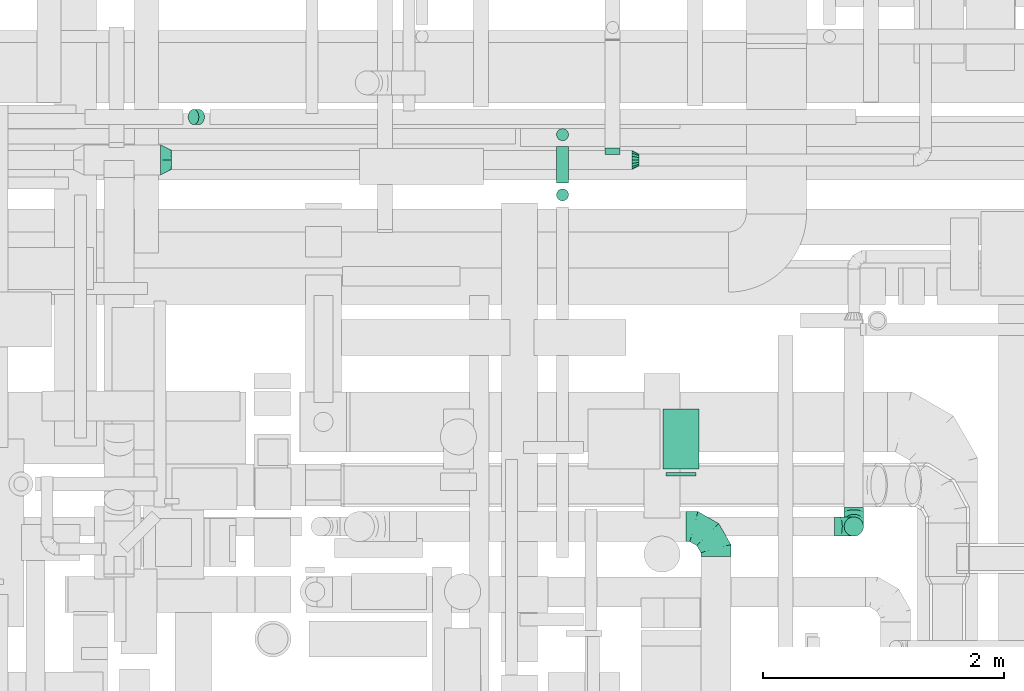
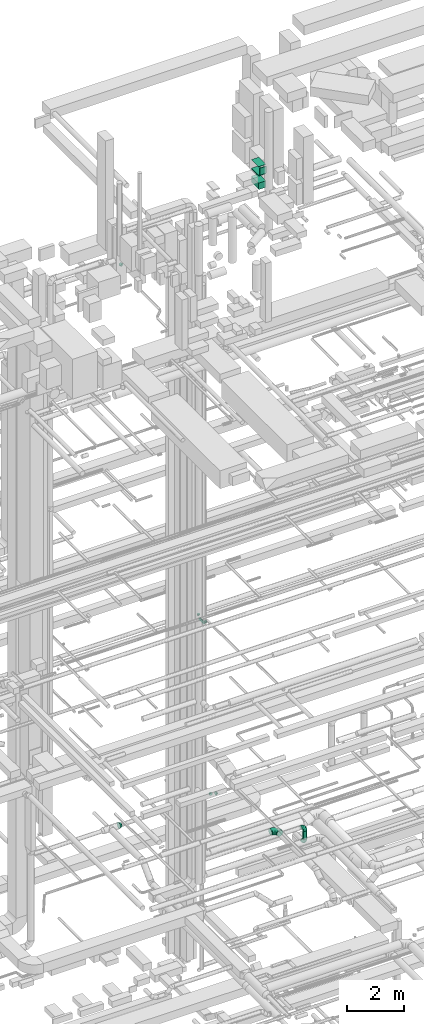
# One storey, part 148 of 337: 9 flow segments, 6 flow fittings.
"""IFC2X3 building model written with IfcOpenShell, lengths in millimetres."""

from ifc_helpers import new_model, entity, si_unit, converted_unit, derived_unit, direction, frame, origin, origin_2d_with_axis, place, context, subcontext, project, spatial, rectangle, circle, extrude, faceted_brep, source, transform, mapped, material, type_object, type_shapes, element, save


model = new_model("IFC2X3")

# Units and contexts
model_context = context("Model", 3, precision=0.01, world=origin(), true_north=direction((6.12303176911189e-17, 1.0)))
body_context = subcontext(model_context, "Body", "Model", "MODEL_VIEW")
ifc_project = project(units=[si_unit("LENGTHUNIT", "METRE", prefix="MILLI"), si_unit("AREAUNIT", "SQUARE_METRE"), si_unit("VOLUMEUNIT", "CUBIC_METRE"), converted_unit("PLANEANGLEUNIT", "DEGREE", entity("IfcRatioMeasure", 0.0174532925199433), si_unit("PLANEANGLEUNIT", "RADIAN"), dimensions=[0, 0, 0, 0, 0, 0, 0]), si_unit("MASSUNIT", "GRAM", prefix="KILO"), derived_unit("MASSDENSITYUNIT", [(si_unit("MASSUNIT", "GRAM", prefix="KILO"), 1), (si_unit("LENGTHUNIT", "METRE"), -3)]), derived_unit("MOMENTOFINERTIAUNIT", [(si_unit("LENGTHUNIT", "METRE"), 4)]), si_unit("TIMEUNIT", "SECOND"), si_unit("FREQUENCYUNIT", "HERTZ"), si_unit("THERMODYNAMICTEMPERATUREUNIT", "DEGREE_CELSIUS"), derived_unit("THERMALTRANSMITTANCEUNIT", [(si_unit("MASSUNIT", "GRAM", prefix="KILO"), 1), (si_unit("THERMODYNAMICTEMPERATUREUNIT", "KELVIN"), -1), (si_unit("TIMEUNIT", "SECOND"), -3)]), derived_unit("VOLUMETRICFLOWRATEUNIT", [(si_unit("LENGTHUNIT", "METRE"), 3), (si_unit("TIMEUNIT", "SECOND"), -1)]), derived_unit("MASSFLOWRATEUNIT", [(si_unit("MASSUNIT", "GRAM", prefix="KILO"), 1), (si_unit("TIMEUNIT", "SECOND"), -1)]), derived_unit("ROTATIONALFREQUENCYUNIT", [(si_unit("TIMEUNIT", "SECOND"), -1)]), si_unit("ELECTRICCURRENTUNIT", "AMPERE"), si_unit("ELECTRICVOLTAGEUNIT", "VOLT"), si_unit("POWERUNIT", "WATT"), si_unit("FORCEUNIT", "NEWTON", prefix="KILO"), si_unit("ILLUMINANCEUNIT", "LUX"), si_unit("LUMINOUSFLUXUNIT", "LUMEN"), si_unit("LUMINOUSINTENSITYUNIT", "CANDELA"), derived_unit("USERDEFINED", [(si_unit("MASSUNIT", "GRAM", prefix="KILO"), -1), (si_unit("LENGTHUNIT", "METRE"), -2), (si_unit("TIMEUNIT", "SECOND"), 3), (si_unit("LUMINOUSFLUXUNIT", "LUMEN"), 1)]), derived_unit("LINEARVELOCITYUNIT", [(si_unit("LENGTHUNIT", "METRE"), 1), (si_unit("TIMEUNIT", "SECOND"), -1)]), si_unit("PRESSUREUNIT", "PASCAL"), derived_unit("USERDEFINED", [(si_unit("LENGTHUNIT", "METRE"), -2), (si_unit("MASSUNIT", "GRAM", prefix="KILO"), 1), (si_unit("TIMEUNIT", "SECOND"), -2)]), derived_unit("LINEARFORCEUNIT", [(si_unit("MASSUNIT", "GRAM", prefix="KILO"), 1), (si_unit("LENGTHUNIT", "METRE"), 1), (si_unit("TIMEUNIT", "SECOND"), -2), (si_unit("LENGTHUNIT", "METRE"), -1)]), derived_unit("PLANARFORCEUNIT", [(si_unit("MASSUNIT", "GRAM", prefix="KILO"), 1), (si_unit("LENGTHUNIT", "METRE"), 1), (si_unit("TIMEUNIT", "SECOND"), -2), (si_unit("LENGTHUNIT", "METRE"), -2)])], contexts=[model_context])

# Site, building, storey
site_placement = place(None, origin())
site = spatial("IfcSite", under=ifc_project, at=site_placement, CompositionType="ELEMENT")
building_placement = place(site_placement, origin())
building = spatial("IfcBuilding", under=site, at=building_placement, CompositionType="ELEMENT")
storey_placement = place(building_placement, origin())
storey = spatial("IfcBuildingStorey", under=building, at=storey_placement, CompositionType="ELEMENT", Elevation=0.0)

# Flow segments
duct_segment_type_1 = type_object("IfcDuctSegmentType", PredefinedType="NOTDEFINED")
flow_segment_1_placement = place(storey_placement, frame((34379.03, 12654.98, 31840.0)))
element("IfcFlowSegment", 1, at=flow_segment_1_placement, inside=storey, type_object=duct_segment_type_1, context=body_context, shape_type="SweptSolid", body=[
    extrude(rectangle(XDim=499.999999999999, YDim=300.000000000001, at=origin_2d_with_axis()), frame((150.0, 250.0, 0.0), z_axis=(0.0, 0.0, 1.0), x_axis=(0.0, -1.0, 0.0)), (0.0, 0.0, 1.0), 15.0000000012614),
])
flow_segment_2_placement = place(storey_placement, frame((34379.03, 12654.98, 30875.0)))
element("IfcFlowSegment", 2, at=flow_segment_2_placement, inside=storey, type_object=duct_segment_type_1, context=body_context, shape_type="SweptSolid", body=[
    extrude(rectangle(XDim=499.999999999999, YDim=300.000000000001, at=origin_2d_with_axis()), frame((150.0, 250.0, 0.0), z_axis=(0.0, 0.0, 1.0), x_axis=(0.0, 1.0, 0.0)), (0.0, 0.0, 1.0), 275.000025000013),
])
flow_segment_3_placement = place(storey_placement, frame((34379.03, 12654.98, 31450.0)))
element("IfcFlowSegment", 3, at=flow_segment_3_placement, inside=storey, type_object=duct_segment_type_1, context=body_context, shape_type="SweptSolid", body=[
    extrude(rectangle(XDim=499.999999999999, YDim=300.000000000001, at=origin_2d_with_axis()), frame((150.0, 250.0, 0.0), z_axis=(0.0, 0.0, 1.0), x_axis=(0.0, 1.0, 0.0)), (0.0, 0.0, 1.0), 39.9999749988413),
])
duct_segment_type_2 = type_object("IfcDuctSegmentType", PredefinedType="NOTDEFINED")
flow_segment_4_placement = place(storey_placement, frame((33494.61, 15383.25, 11300.0)))
element("IfcFlowSegment", 4, at=flow_segment_4_placement, inside=storey, type_object=duct_segment_type_2, context=body_context, shape_type="SweptSolid", body=[
    extrude(circle(Radius=50.0, at=origin_2d_with_axis()), frame((51.6, 51.6, 0.0), z_axis=(0.0, 0.0, 1.0), x_axis=(-1.0, 0.0, 0.0)), (0.0, 0.0, 1.0), 49.9999999999713),
])
flow_segment_5_placement = place(storey_placement, frame((33494.61, 15034.85, 11148.4)))
element("IfcFlowSegment", 5, at=flow_segment_5_placement, inside=storey, type_object=duct_segment_type_2, context=body_context, shape_type="SweptSolid", body=[
    extrude(circle(Radius=50.0, at=origin_2d_with_axis()), frame((51.6, 0.0, 51.6), z_axis=(0.0, 1.0, 0.0), x_axis=(-1.0, 0.0, 0.0)), (0.0, 0.0, 1.0), 300.000000000005),
])
flow_segment_6_placement = place(storey_placement, frame((33494.61, 14883.25, 11300.0)))
element("IfcFlowSegment", 6, at=flow_segment_6_placement, inside=storey, type_object=duct_segment_type_2, context=body_context, shape_type="SweptSolid", body=[
    extrude(circle(Radius=50.0, at=origin_2d_with_axis()), frame((51.6, 51.6, 0.0), z_axis=(0.0, 0.0, 1.0), x_axis=(-1.0, 0.0, 0.0)), (0.0, 0.0, 1.0), 50.000000000019),
])
flow_segment_7_placement = place(storey_placement, frame((35884.48, 12097.06, 2880.0)))
element("IfcFlowSegment", 7, at=flow_segment_7_placement, inside=storey, type_object=duct_segment_type_2, context=body_context, shape_type="SweptSolid", body=[
    extrude(circle(Radius=80.0, at=origin_2d_with_axis()), frame((81.6, 81.6, 0.0), z_axis=(0.0, 0.0, 1.0), x_axis=(0.0, 1.0, 0.0)), (0.0, 0.0, 1.0), 360.000000000001),
])
flow_segment_8_placement = place(storey_placement, frame((30434.24, 15517.89, 27190.82)))
element("IfcFlowSegment", 8, at=flow_segment_8_placement, inside=storey, type_object=duct_segment_type_2, context=body_context, shape_type="SweptSolid", body=[
    extrude(circle(Radius=62.5, at=origin_2d_with_axis()), frame((45.79, 64.1, 92.57), z_axis=(0.707106074078693, 0.0, -0.707107488293695), x_axis=(0.0, 1.0, 0.0)), (0.0, 0.0, 1.0), 66.1519207391797),
])
duct_segment_type_3 = type_object("IfcDuctSegmentType", PredefinedType="NOTDEFINED")
flow_segment_9_placement = place(storey_placement, frame((34404.03, 12599.6, 31515.0)))
element("IfcFlowSegment", 9, at=flow_segment_9_placement, inside=storey, type_object=duct_segment_type_3, context=body_context, shape_type="SweptSolid", body=[
    extrude(rectangle(XDim=30.3811905327621, YDim=249.999999999999, at=origin_2d_with_axis()), frame((125.0, 15.19, 0.0), z_axis=(0.0, 0.0, 1.0), x_axis=(0.0, 1.0, 0.0)), (0.0, 0.0, 1.0), 300.000000000001),
])

# Flow fittings
ifc_material = material()
duct_fitting_type_1 = type_object("IfcDuctFittingType", PredefinedType="NOTDEFINED", material=ifc_material)
shared_shape_1 = source(origin(), body_context, "Body", "Brep", [
    faceted_brep([(-160.0, 0.0, -80.0), (-160.0, -20.71, -77.27), (-160.0, -40.0, -69.28), (-160.0, -56.57, -56.57), (-160.0, -69.28, -40.0), (-160.0, -77.27, -20.71), (-160.0, -80.0, 0.0), (-160.0, -77.27, 20.71), (-160.0, -69.28, 40.0), (-160.0, -56.57, 56.57), (-160.0, -40.0, 69.28), (-160.0, -20.71, 77.27), (-160.0, 0.0, 80.0), (-160.0, 20.71, 77.27), (-160.0, 40.0, 69.28), (-160.0, 56.57, 56.57), (-160.0, 69.28, 40.0), (-160.0, 77.27, 20.71), (-160.0, 80.0, 0.0), (-160.0, 77.27, -20.71), (-160.0, 69.28, -40.0), (-160.0, 56.57, -56.57), (-160.0, 40.0, -69.28), (-160.0, 20.71, -77.27), (-122.68, 20.71, 77.27), (-127.85, 40.0, 69.28), (-117.13, 0.0, 80.0), (-132.29, 56.57, 56.57), (-137.83, 77.27, 20.71), (-138.56, 80.0, 0.0), (-135.69, 69.28, 40.0), (-135.69, 69.28, -40.0), (-132.29, 56.57, -56.57), (-137.83, 77.27, -20.71), (-122.68, 20.71, -77.27), (-117.13, 0.0, -80.0), (-127.85, 40.0, -69.28), (-111.58, -20.71, -77.27), (-106.41, -40.0, -69.28), (-101.97, -56.57, -56.57), (-98.56, -69.28, -40.0), (-96.42, -77.27, -20.71), (-95.69, -80.0, 0.0), (-96.42, -77.27, 20.71), (-98.56, -69.28, 40.0), (-101.97, -56.57, 56.57), (-106.41, -40.0, 69.28), (-111.58, -20.71, 77.27), (-58.03, 58.03, 77.27), (-72.15, 72.15, 69.28), (-42.87, 42.87, 80.0), (-84.28, 84.28, 56.57), (-93.59, 93.59, 40.0), (-99.44, 99.44, 20.71), (-101.44, 101.44, 0.0), (-99.44, 99.44, -20.71), (-93.59, 93.59, -40.0), (-84.28, 84.28, -56.57), (-58.03, 58.03, -77.27), (-42.87, 42.87, -80.0), (-72.15, 72.15, -69.28), (-27.71, 27.71, -77.27), (-13.59, 13.59, -69.28), (-1.46, 1.46, -56.57), (7.85, -7.85, -40.0), (13.7, -13.7, -20.71), (15.69, -15.69, 0.0), (13.7, -13.7, 20.71), (7.85, -7.85, 40.0), (-1.46, 1.46, 56.57), (-13.59, 13.59, 69.28), (-27.71, 27.71, 77.27), (-20.71, 122.68, 77.27), (-40.0, 127.85, 69.28), (0.0, 117.13, 80.0), (-56.57, 132.29, 56.57), (-69.28, 135.69, 40.0), (-77.27, 137.83, 20.71), (-80.0, 138.56, 0.0), (-77.27, 137.83, -20.71), (-69.28, 135.69, -40.0), (-56.57, 132.29, -56.57), (-20.71, 122.68, -77.27), (0.0, 117.13, -80.0), (-40.0, 127.85, -69.28), (20.71, 111.58, -77.27), (40.0, 106.41, -69.28), (56.57, 101.97, -56.57), (69.28, 98.56, -40.0), (77.27, 96.42, -20.71), (80.0, 95.69, 0.0), (77.27, 96.42, 20.71), (69.28, 98.56, 40.0), (56.57, 101.97, 56.57), (40.0, 106.41, 69.28), (20.71, 111.58, 77.27), (-20.71, 160.0, -77.27), (-40.0, 160.0, -69.28), (-56.57, 160.0, -56.57), (-69.28, 160.0, -40.0), (-77.27, 160.0, -20.71), (-80.0, 160.0, 0.0), (-77.27, 160.0, 20.71), (-69.28, 160.0, 40.0), (-56.57, 160.0, 56.57), (-40.0, 160.0, 69.28), (-20.71, 160.0, 77.27), (0.0, 160.0, 80.0), (20.71, 160.0, 77.27), (40.0, 160.0, 69.28), (56.57, 160.0, 56.57), (69.28, 160.0, 40.0), (77.27, 160.0, 20.71), (80.0, 160.0, 0.0), (77.27, 160.0, -20.71), (69.28, 160.0, -40.0), (56.57, 160.0, -56.57), (40.0, 160.0, -69.28), (20.71, 160.0, -77.27), (0.0, 160.0, -80.0)], [[[0, 1, 2, 3, 4, 5, 6, 7, 8, 9, 10, 11, 12, 13, 14, 15, 16, 17, 18, 19, 20, 21, 22, 23]], [[24, 25, 14, 13]], [[26, 24, 13, 12]], [[14, 25, 27, 15]], [[28, 29, 18, 17]], [[30, 28, 17, 16]], [[15, 27, 30, 16]], [[20, 31, 32, 21]], [[33, 31, 20, 19]], [[18, 29, 33, 19]], [[34, 35, 0, 23]], [[36, 34, 23, 22]], [[32, 36, 22, 21]], [[1, 0, 35, 37]], [[2, 1, 37, 38]], [[3, 2, 38, 39]], [[5, 4, 40, 41]], [[6, 5, 41, 42]], [[39, 40, 4, 3]], [[6, 42, 43, 7]], [[7, 43, 44, 8]], [[8, 44, 45, 9]], [[9, 45, 46, 10]], [[10, 46, 47, 11]], [[26, 12, 11, 47]], [[48, 49, 25, 24]], [[50, 48, 24, 26]], [[27, 25, 49, 51]], [[52, 53, 28, 30]], [[51, 52, 30, 27]], [[29, 28, 53, 54]], [[55, 56, 31, 33]], [[54, 55, 33, 29]], [[32, 31, 56, 57]], [[58, 59, 35, 34]], [[60, 58, 34, 36]], [[57, 60, 36, 32]], [[37, 35, 59, 61]], [[38, 37, 61, 62]], [[39, 38, 62, 63]], [[41, 40, 64, 65]], [[42, 41, 65, 66]], [[63, 64, 40, 39]], [[43, 42, 66, 67]], [[44, 43, 67, 68]], [[68, 69, 45, 44]], [[46, 45, 69, 70]], [[47, 46, 70, 71]], [[26, 47, 71, 50]], [[72, 73, 49, 48]], [[74, 72, 48, 50]], [[51, 49, 73, 75]], [[76, 77, 53, 52]], [[75, 76, 52, 51]], [[54, 53, 77, 78]], [[79, 80, 56, 55]], [[78, 79, 55, 54]], [[57, 56, 80, 81]], [[82, 83, 59, 58]], [[84, 82, 58, 60]], [[81, 84, 60, 57]], [[61, 59, 83, 85]], [[62, 61, 85, 86]], [[63, 62, 86, 87]], [[65, 64, 88, 89]], [[66, 65, 89, 90]], [[87, 88, 64, 63]], [[67, 66, 90, 91]], [[68, 67, 91, 92]], [[92, 93, 69, 68]], [[70, 69, 93, 94]], [[71, 70, 94, 95]], [[50, 71, 95, 74]], [[96, 97, 98, 99, 100, 101, 102, 103, 104, 105, 106, 107, 108, 109, 110, 111, 112, 113, 114, 115, 116, 117, 118, 119]], [[72, 74, 107, 106]], [[73, 72, 106, 105]], [[75, 73, 105, 104]], [[77, 76, 103, 102]], [[78, 77, 102, 101]], [[75, 104, 103, 76]], [[78, 101, 100, 79]], [[79, 100, 99, 80]], [[80, 99, 98, 81]], [[84, 97, 96, 82]], [[82, 96, 119, 83]], [[84, 81, 98, 97]], [[118, 117, 86, 85]], [[119, 118, 85, 83]], [[116, 87, 86, 117]], [[88, 115, 114, 89]], [[89, 114, 113, 90]], [[115, 88, 87, 116]], [[112, 111, 92, 91]], [[113, 112, 91, 90]], [[111, 110, 93, 92]], [[95, 94, 109, 108]], [[74, 95, 108, 107]], [[110, 109, 94, 93]]]),
])
type_shapes(duct_fitting_type_1, [shared_shape_1])
for number, where, z_axis, x_axis in (
    (10, (35966.08, 12178.65, 2720.0), (-1.0, 0.0, 0.0), (0.0, -1.0, 0.0)),
    (11, (35966.08, 12178.65, 3400.0), (0.0, -1.0, 0.0), (0.0, 0.0, 1.0)),
):
    element("IfcFlowFitting", number, at=place(storey_placement, frame(where, z_axis=z_axis, x_axis=x_axis)), inside=storey, type_object=duct_fitting_type_1, material=ifc_material, context=body_context, shape_type="MappedRepresentation", body=[
        mapped(shared_shape_1, transform((0.0, 0.0, 0.0), scale=1.0)),
    ])
duct_fitting_type_2 = type_object("IfcDuctFittingType", PredefinedType="NOTDEFINED", material=ifc_material)
shared_shape_2 = source(origin(), body_context, "Body", "Brep", [
    faceted_brep([(-250.0, 0.0, -125.0), (-250.0, -32.35, -120.74), (-250.0, -62.5, -108.25), (-250.0, -88.39, -88.39), (-250.0, -108.25, -62.5), (-250.0, -120.74, -32.35), (-250.0, -125.0, 0.0), (-250.0, -120.74, 32.35), (-250.0, -108.25, 62.5), (-250.0, -88.39, 88.39), (-250.0, -62.5, 108.25), (-250.0, -32.35, 120.74), (-250.0, 0.0, 125.0), (-250.0, 32.35, 120.74), (-250.0, 62.5, 108.25), (-250.0, 88.39, 88.39), (-250.0, 108.25, 62.5), (-250.0, 120.74, 32.35), (-250.0, 125.0, 0.0), (-250.0, 120.74, -32.35), (-250.0, 108.25, -62.5), (-250.0, 88.39, -88.39), (-250.0, 62.5, -108.25), (-250.0, 32.35, -120.74), (-191.68, 32.35, 120.74), (-199.76, 62.5, 108.25), (-183.01, 0.0, 125.0), (-206.7, 88.39, 88.39), (-215.37, 120.74, 32.35), (-216.51, 125.0, 0.0), (-212.02, 108.25, 62.5), (-212.02, 108.25, -62.5), (-206.7, 88.39, -88.39), (-215.37, 120.74, -32.35), (-191.68, 32.35, -120.74), (-183.01, 0.0, -125.0), (-199.76, 62.5, -108.25), (-174.34, -32.35, -120.74), (-166.27, -62.5, -108.25), (-159.33, -88.39, -88.39), (-154.01, -108.25, -62.5), (-150.66, -120.74, -32.35), (-149.52, -125.0, 0.0), (-150.66, -120.74, 32.35), (-154.01, -108.25, 62.5), (-159.33, -88.39, 88.39), (-166.27, -62.5, 108.25), (-174.34, -32.35, 120.74), (-90.67, 90.67, 120.74), (-112.74, 112.74, 108.25), (-66.99, 66.99, 125.0), (-131.69, 131.69, 88.39), (-146.23, 146.23, 62.5), (-155.38, 155.38, 32.35), (-158.49, 158.49, 0.0), (-155.38, 155.38, -32.35), (-146.23, 146.23, -62.5), (-131.69, 131.69, -88.39), (-90.67, 90.67, -120.74), (-66.99, 66.99, -125.0), (-112.74, 112.74, -108.25), (-43.3, 43.3, -120.74), (-21.23, 21.23, -108.25), (-2.28, 2.28, -88.39), (12.26, -12.26, -62.5), (21.4, -21.4, -32.35), (24.52, -24.52, 0.0), (21.4, -21.4, 32.35), (12.26, -12.26, 62.5), (-2.28, 2.28, 88.39), (-21.23, 21.23, 108.25), (-43.3, 43.3, 120.74), (-32.35, 191.68, 120.74), (-62.5, 199.76, 108.25), (0.0, 183.01, 125.0), (-88.39, 206.7, 88.39), (-108.25, 212.02, 62.5), (-120.74, 215.37, 32.35), (-125.0, 216.51, 0.0), (-120.74, 215.37, -32.35), (-108.25, 212.02, -62.5), (-88.39, 206.7, -88.39), (-32.35, 191.68, -120.74), (0.0, 183.01, -125.0), (-62.5, 199.76, -108.25), (32.35, 174.34, -120.74), (62.5, 166.27, -108.25), (88.39, 159.33, -88.39), (108.25, 154.01, -62.5), (120.74, 150.66, -32.35), (125.0, 149.52, 0.0), (120.74, 150.66, 32.35), (108.25, 154.01, 62.5), (88.39, 159.33, 88.39), (62.5, 166.27, 108.25), (32.35, 174.34, 120.74), (-32.35, 250.0, -120.74), (-62.5, 250.0, -108.25), (-88.39, 250.0, -88.39), (-108.25, 250.0, -62.5), (-120.74, 250.0, -32.35), (-125.0, 250.0, 0.0), (-120.74, 250.0, 32.35), (-108.25, 250.0, 62.5), (-88.39, 250.0, 88.39), (-62.5, 250.0, 108.25), (-32.35, 250.0, 120.74), (0.0, 250.0, 125.0), (32.35, 250.0, 120.74), (62.5, 250.0, 108.25), (88.39, 250.0, 88.39), (108.25, 250.0, 62.5), (120.74, 250.0, 32.35), (125.0, 250.0, 0.0), (120.74, 250.0, -32.35), (108.25, 250.0, -62.5), (88.39, 250.0, -88.39), (62.5, 250.0, -108.25), (32.35, 250.0, -120.74), (0.0, 250.0, -125.0)], [[[0, 1, 2, 3, 4, 5, 6, 7, 8, 9, 10, 11, 12, 13, 14, 15, 16, 17, 18, 19, 20, 21, 22, 23]], [[24, 25, 14, 13]], [[26, 24, 13, 12]], [[14, 25, 27, 15]], [[28, 29, 18, 17]], [[30, 28, 17, 16]], [[15, 27, 30, 16]], [[20, 31, 32, 21]], [[33, 31, 20, 19]], [[18, 29, 33, 19]], [[34, 35, 0, 23]], [[36, 34, 23, 22]], [[21, 32, 36, 22]], [[1, 0, 35, 37]], [[2, 1, 37, 38]], [[38, 39, 3, 2]], [[5, 4, 40, 41]], [[6, 5, 41, 42]], [[39, 40, 4, 3]], [[6, 42, 43, 7]], [[7, 43, 44, 8]], [[8, 44, 45, 9]], [[9, 45, 46, 10]], [[10, 46, 47, 11]], [[26, 12, 11, 47]], [[48, 49, 25, 24]], [[50, 48, 24, 26]], [[27, 25, 49, 51]], [[52, 53, 28, 30]], [[51, 52, 30, 27]], [[29, 28, 53, 54]], [[55, 56, 31, 33]], [[54, 55, 33, 29]], [[32, 31, 56, 57]], [[58, 59, 35, 34]], [[60, 58, 34, 36]], [[57, 60, 36, 32]], [[37, 35, 59, 61]], [[38, 37, 61, 62]], [[39, 38, 62, 63]], [[41, 40, 64, 65]], [[42, 41, 65, 66]], [[63, 64, 40, 39]], [[43, 42, 66, 67]], [[44, 43, 67, 68]], [[68, 69, 45, 44]], [[46, 45, 69, 70]], [[47, 46, 70, 71]], [[26, 47, 71, 50]], [[72, 73, 49, 48]], [[74, 72, 48, 50]], [[51, 49, 73, 75]], [[76, 77, 53, 52]], [[75, 76, 52, 51]], [[54, 53, 77, 78]], [[79, 80, 56, 55]], [[78, 79, 55, 54]], [[57, 56, 80, 81]], [[82, 83, 59, 58]], [[84, 82, 58, 60]], [[81, 84, 60, 57]], [[61, 59, 83, 85]], [[62, 61, 85, 86]], [[63, 62, 86, 87]], [[65, 64, 88, 89]], [[66, 65, 89, 90]], [[87, 88, 64, 63]], [[67, 66, 90, 91]], [[68, 67, 91, 92]], [[92, 93, 69, 68]], [[70, 69, 93, 94]], [[71, 70, 94, 95]], [[50, 71, 95, 74]], [[96, 97, 98, 99, 100, 101, 102, 103, 104, 105, 106, 107, 108, 109, 110, 111, 112, 113, 114, 115, 116, 117, 118, 119]], [[72, 74, 107, 106]], [[73, 72, 106, 105]], [[75, 73, 105, 104]], [[77, 76, 103, 102]], [[78, 77, 102, 101]], [[75, 104, 103, 76]], [[78, 101, 100, 79]], [[79, 100, 99, 80]], [[80, 99, 98, 81]], [[84, 97, 96, 82]], [[82, 96, 119, 83]], [[84, 81, 98, 97]], [[83, 119, 118, 85]], [[85, 118, 117, 86]], [[116, 87, 86, 117]], [[88, 115, 114, 89]], [[89, 114, 113, 90]], [[115, 88, 87, 116]], [[91, 90, 113, 112]], [[92, 91, 112, 111]], [[111, 110, 93, 92]], [[95, 94, 109, 108]], [[74, 95, 108, 107]], [[110, 109, 94, 93]]]),
])
type_shapes(duct_fitting_type_2, [shared_shape_2])
flow_fitting_1_placement = place(storey_placement, frame((34820.41, 12178.65, 3650.0), z_axis=(0.0, 0.0, 1.0), x_axis=(0.0, 1.0, 0.0)))
element("IfcFlowFitting", 12, at=flow_fitting_1_placement, inside=storey, type_object=duct_fitting_type_2, material=ifc_material, context=body_context, shape_type="MappedRepresentation", body=[
    mapped(shared_shape_2, transform((0.0, 0.0, 0.0), scale=1.0)),
])
duct_fitting_type_3 = type_object("IfcDuctFittingType", PredefinedType="NOTDEFINED", material=ifc_material)
shared_shape_3 = source(origin(), body_context, "Body", "Brep", [
    faceted_brep([(60.0, 0.0, -80.0), (60.0, 14.27, -77.16), (60.0, 30.61, -73.91), (60.0, 43.59, -65.24), (60.0, 56.57, -56.57), (60.0, 65.24, -43.59), (60.0, 73.91, -30.61), (60.0, 77.16, -14.27), (60.0, 80.0, 0.0), (60.0, 77.16, 14.27), (60.0, 73.91, 30.61), (60.0, 65.24, 43.59), (60.0, 56.57, 56.57), (60.0, 43.59, 65.24), (60.0, 30.61, 73.91), (60.0, 14.27, 77.16), (60.0, 0.0, 80.0), (60.0, -14.27, 77.16), (60.0, -30.61, 73.91), (60.0, -43.59, 65.24), (60.0, -56.57, 56.57), (60.0, -65.24, 43.59), (60.0, -73.91, 30.61), (60.0, -77.16, 14.27), (60.0, -80.0, 0.0), (60.0, -77.16, -14.27), (60.0, -73.91, -30.61), (60.0, -65.24, -43.59), (60.0, -56.57, -56.57), (60.0, -43.59, -65.24), (60.0, -30.61, -73.91), (60.0, -14.27, -77.16), (0.0, -19.13, -46.19), (0.0, -27.24, -40.77), (0.0, -35.36, -35.36), (0.0, -40.77, -27.24), (0.0, -46.19, -19.13), (0.0, -48.1, -9.57), (0.0, -50.0, 0.0), (0.0, -48.1, 9.57), (0.0, -46.19, 19.13), (0.0, -40.77, 27.24), (0.0, -35.36, 35.36), (0.0, -27.24, 40.77), (0.0, -19.13, 46.19), (0.0, -9.57, 48.1), (0.0, 0.0, 50.0), (0.0, 9.57, 48.1), (0.0, 19.13, 46.19), (0.0, 27.24, 40.77), (0.0, 35.36, 35.36), (0.0, 40.77, 27.24), (0.0, 46.19, 19.13), (0.0, 48.1, 9.57), (0.0, 50.0, 0.0), (0.0, 48.1, -9.57), (0.0, 46.19, -19.13), (0.0, 40.77, -27.24), (0.0, 35.36, -35.36), (0.0, 27.24, -40.77), (0.0, 19.13, -46.19), (0.0, 9.57, -48.1), (0.0, 0.0, -50.0), (0.0, -9.57, -48.1)], [[[0, 1, 2, 3, 4, 5, 6, 7, 8, 9, 10, 11, 12, 13, 14, 15, 16, 17, 18, 19, 20, 21, 22, 23, 24, 25, 26, 27, 28, 29, 30, 31]], [[32, 33, 34, 35, 36, 37, 38, 39, 40, 41, 42, 43, 44, 45, 46, 47, 48, 49, 50, 51, 52, 53, 54, 55, 56, 57, 58, 59, 60, 61, 62, 63]], [[52, 51, 50, 12, 11, 10]], [[48, 14, 13, 12, 50, 49]], [[10, 9, 8, 54, 53, 52]], [[15, 14, 48, 47, 46, 16]], [[44, 43, 42, 20, 19, 18]], [[40, 22, 21, 20, 42, 41]], [[18, 17, 16, 46, 45, 44]], [[23, 22, 40, 39, 38, 24]], [[36, 35, 34, 28, 27, 26]], [[32, 30, 29, 28, 34, 33]], [[26, 25, 24, 38, 37, 36]], [[31, 30, 32, 63, 62, 0]], [[60, 59, 58, 4, 3, 2]], [[56, 6, 5, 4, 58, 57]], [[2, 1, 0, 62, 61, 60]], [[7, 6, 56, 55, 54, 8]]]),
])
type_shapes(duct_fitting_type_3, [shared_shape_3])
flow_fitting_2_placement = place(storey_placement, frame((34181.25, 15224.94, 3600.0), z_axis=(0.0, 0.0, 1.0), x_axis=(-1.0, 0.0, 0.0)))
element("IfcFlowFitting", 13, at=flow_fitting_2_placement, inside=storey, type_object=duct_fitting_type_3, material=ifc_material, context=body_context, shape_type="MappedRepresentation", body=[
    mapped(shared_shape_3, transform((0.0, 0.0, 0.0), scale=1.0)),
])
duct_fitting_type_4 = type_object("IfcDuctFittingType", PredefinedType="NOTDEFINED", material=ifc_material)
shared_shape_4 = source(origin(), body_context, "Body", "Brep", [
    faceted_brep([(90.0, -73.91, 30.61), (90.0, -76.96, 15.31), (90.0, -80.0, 0.0), (90.0, -76.96, -15.31), (90.0, -73.91, -30.61), (90.0, -65.24, -43.59), (90.0, -56.57, -56.57), (90.0, -43.59, -65.24), (90.0, -30.61, -73.91), (90.0, -15.31, -76.96), (90.0, 0.0, -80.0), (90.0, 15.31, -76.96), (90.0, 30.61, -73.91), (90.0, 43.59, -65.24), (90.0, 56.57, -56.57), (90.0, 65.24, -43.59), (90.0, 73.91, -30.61), (90.0, 76.96, -15.31), (90.0, 80.0, 0.0), (90.0, 76.96, 15.31), (90.0, 73.91, 30.61), (90.0, 65.24, 43.59), (90.0, 56.57, 56.57), (90.0, 43.59, 65.24), (90.0, 30.61, 73.91), (90.0, 15.31, 76.96), (90.0, 0.0, 80.0), (90.0, -15.31, 76.96), (90.0, -30.61, 73.91), (90.0, -43.59, 65.24), (90.0, -56.57, 56.57), (90.0, -65.24, 43.59), (0.0, -125.0, 0.0), (0.0, -118.88, 38.63), (0.0, -101.13, 73.47), (0.0, -73.47, 101.13), (0.0, -38.63, 118.88), (0.0, 0.0, 125.0), (0.0, 38.63, 118.88), (0.0, 73.47, 101.13), (0.0, 101.13, 73.47), (0.0, 118.88, 38.63), (0.0, 125.0, 0.0), (0.0, 118.88, -38.63), (0.0, 101.13, -73.47), (0.0, 73.47, -101.13), (0.0, 38.63, -118.88), (0.0, 0.0, -125.0), (0.0, -38.63, -118.88), (0.0, -73.47, -101.13), (0.0, -101.13, -73.47), (0.0, -118.88, -38.63)], [[[0, 1, 2, 3, 4, 5, 6, 7, 8, 9, 10, 11, 12, 13, 14, 15, 16, 17, 18, 19, 20, 21, 22, 23, 24, 25, 26, 27, 28, 29, 30, 31]], [[32, 33, 34, 35, 36, 37, 38, 39, 40, 41, 42, 43, 44, 45, 46, 47, 48, 49, 50, 51]], [[37, 25, 38]], [[24, 39, 38]], [[40, 22, 21, 20]], [[23, 22, 39, 24]], [[41, 20, 19]], [[18, 42, 19]], [[25, 24, 38]], [[40, 20, 41]], [[19, 42, 41]], [[25, 37, 26]], [[22, 40, 39]], [[32, 1, 33]], [[0, 34, 33]], [[35, 30, 29, 28]], [[31, 30, 34, 0]], [[36, 28, 27]], [[26, 37, 27]], [[1, 0, 33]], [[35, 28, 36]], [[27, 37, 36]], [[1, 32, 2]], [[30, 35, 34]], [[47, 9, 48]], [[8, 49, 48]], [[50, 6, 5, 4]], [[7, 6, 49, 8]], [[51, 4, 3]], [[2, 32, 3]], [[9, 8, 48]], [[50, 4, 51]], [[3, 32, 51]], [[9, 47, 10]], [[6, 50, 49]], [[42, 17, 43]], [[16, 44, 43]], [[45, 14, 13, 12]], [[15, 14, 44, 16]], [[46, 12, 11]], [[10, 47, 11]], [[17, 16, 43]], [[45, 12, 46]], [[11, 47, 46]], [[17, 42, 18]], [[14, 45, 44]]]),
])
type_shapes(duct_fitting_type_4, [shared_shape_4])
flow_fitting_3_placement = place(storey_placement, frame((30206.25, 15224.94, 3600.0)))
element("IfcFlowFitting", 14, at=flow_fitting_3_placement, inside=storey, type_object=duct_fitting_type_4, material=ifc_material, context=body_context, shape_type="MappedRepresentation", body=[
    mapped(shared_shape_4, transform((0.0, 0.0, 0.0), scale=1.0)),
])
duct_fitting_type_5 = type_object("IfcDuctFittingType", PredefinedType="NOTDEFINED", material=ifc_material)
shared_shape_5 = source(origin(), body_context, "Body", "Brep", [
    faceted_brep([(20.0, 0.0, -62.5), (20.0, 16.18, -60.37), (20.0, 31.25, -54.13), (20.0, 44.19, -44.19), (20.0, 54.13, -31.25), (20.0, 60.37, -16.18), (20.0, 62.5, 0.0), (20.0, 60.37, 16.18), (20.0, 54.13, 31.25), (20.0, 44.19, 44.19), (20.0, 31.25, 54.13), (20.0, 16.18, 60.37), (20.0, 0.0, 62.5), (20.0, -16.18, 60.37), (20.0, -31.25, 54.13), (20.0, -44.19, 44.19), (20.0, -54.13, 31.25), (20.0, -60.37, 16.18), (20.0, -62.5, 0.0), (20.0, -60.37, -16.18), (20.0, -54.13, -31.25), (20.0, -44.19, -44.19), (20.0, -31.25, -54.13), (20.0, -16.18, -60.37), (0.0, 0.0, 62.5), (-36.16, 0.0, 62.5), (-36.16, -16.18, 60.37), (0.0, -16.18, 60.37), (-36.16, -31.25, 54.13), (0.0, -31.25, 54.13), (0.0, -44.19, 44.19), (-36.16, -44.19, 44.19), (0.0, -54.13, 31.25), (-36.16, -54.13, 31.25), (-36.16, -60.37, 16.18), (0.0, -60.37, 16.18), (-36.16, -62.5, 0.0), (0.0, -62.5, 0.0), (-36.16, -60.37, -16.18), (0.0, -60.37, -16.18), (-36.16, -54.13, -31.25), (0.0, -54.13, -31.25), (0.0, -44.19, -44.19), (-36.16, -44.19, -44.19), (0.0, -31.25, -54.13), (-36.16, -31.25, -54.13), (-36.16, -16.18, -60.37), (0.0, -16.18, -60.37), (-36.16, 0.0, -62.5), (0.0, 0.0, -62.5), (-36.16, 16.18, -60.37), (0.0, 16.18, -60.37), (-36.16, 31.25, -54.13), (0.0, 31.25, -54.13), (0.0, 44.19, -44.19), (-36.16, 44.19, -44.19), (0.0, 54.13, -31.25), (-36.16, 54.13, -31.25), (-36.16, 60.37, -16.18), (0.0, 60.37, -16.18), (-36.16, 62.5, 0.0), (0.0, 62.5, 0.0), (-36.16, 60.37, 16.18), (0.0, 60.37, 16.18), (-36.16, 54.13, 31.25), (0.0, 54.13, 31.25), (0.0, 44.19, 44.19), (-36.16, 44.19, 44.19), (0.0, 31.25, 54.13), (-36.16, 31.25, 54.13), (-36.16, 16.18, 60.37), (0.0, 16.18, 60.37)], [[[0, 1, 2, 3, 4, 5, 6, 7, 8, 9, 10, 11, 12, 13, 14, 15, 16, 17, 18, 19, 20, 21, 22, 23]], [[13, 12, 24, 25, 26, 27]], [[14, 13, 27, 26, 28, 29]], [[30, 15, 14, 29, 28, 31]], [[17, 16, 32, 33, 34, 35]], [[18, 17, 35, 34, 36, 37]], [[32, 16, 15, 30, 31, 33]], [[19, 18, 37, 36, 38, 39]], [[20, 19, 39, 38, 40, 41]], [[42, 21, 20, 41, 40, 43]], [[23, 22, 44, 45, 46, 47]], [[0, 23, 47, 46, 48, 49]], [[44, 22, 21, 42, 43, 45]], [[1, 0, 49, 48, 50, 51]], [[2, 1, 51, 50, 52, 53]], [[54, 3, 2, 53, 52, 55]], [[5, 4, 56, 57, 58, 59]], [[6, 5, 59, 58, 60, 61]], [[56, 4, 3, 54, 55, 57]], [[7, 6, 61, 60, 62, 63]], [[8, 7, 63, 62, 64, 65]], [[66, 9, 8, 65, 64, 67]], [[11, 10, 68, 69, 70, 71]], [[12, 11, 71, 70, 25, 24]], [[68, 10, 9, 66, 67, 69]], [[46, 45, 43, 40, 38, 36, 34, 33, 31, 28, 26, 25, 70, 69, 67, 64, 62, 60, 58, 57, 55, 52, 50, 48]]]),
])
type_shapes(duct_fitting_type_5, [shared_shape_5])
flow_fitting_4_placement = place(storey_placement, frame((33962.52, 15304.94, 3600.0), z_axis=(0.0, 0.0, -1.0), x_axis=(0.0, 1.0, 0.0)))
element("IfcFlowFitting", 15, at=flow_fitting_4_placement, inside=storey, type_object=duct_fitting_type_5, material=ifc_material, context=body_context, shape_type="MappedRepresentation", body=[
    mapped(shared_shape_5, transform((0.0, 0.0, 0.0), scale=1.0)),
])

save(model, "model.ifc")
